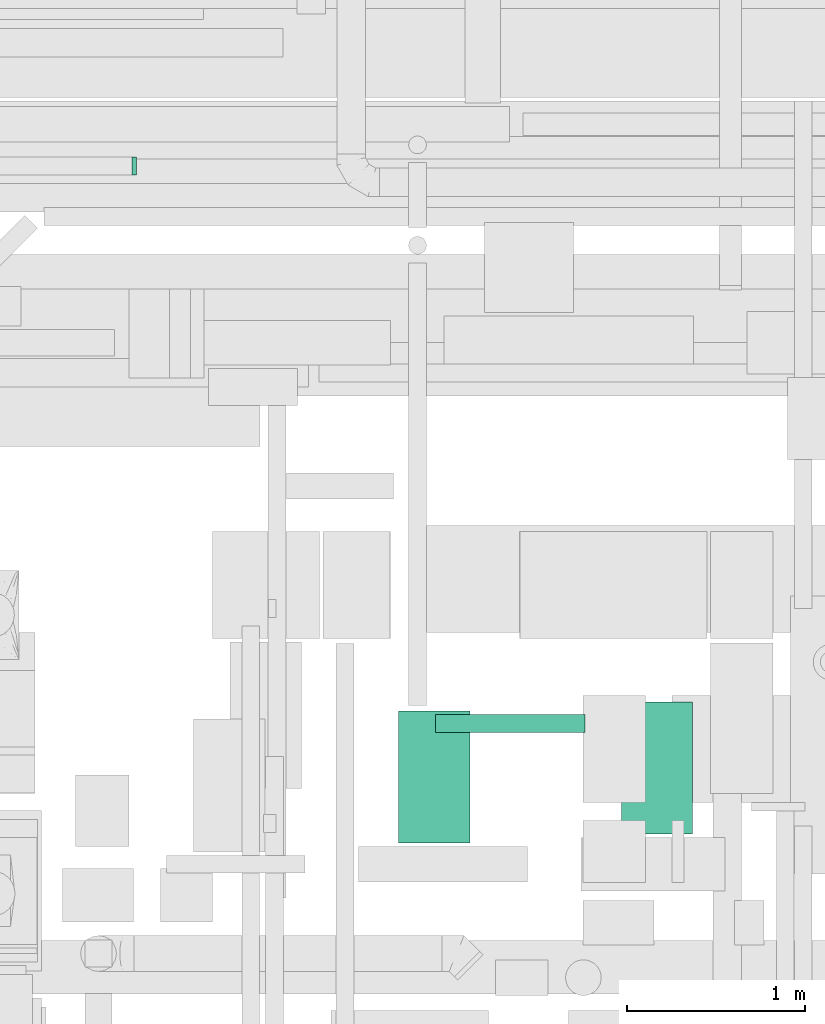
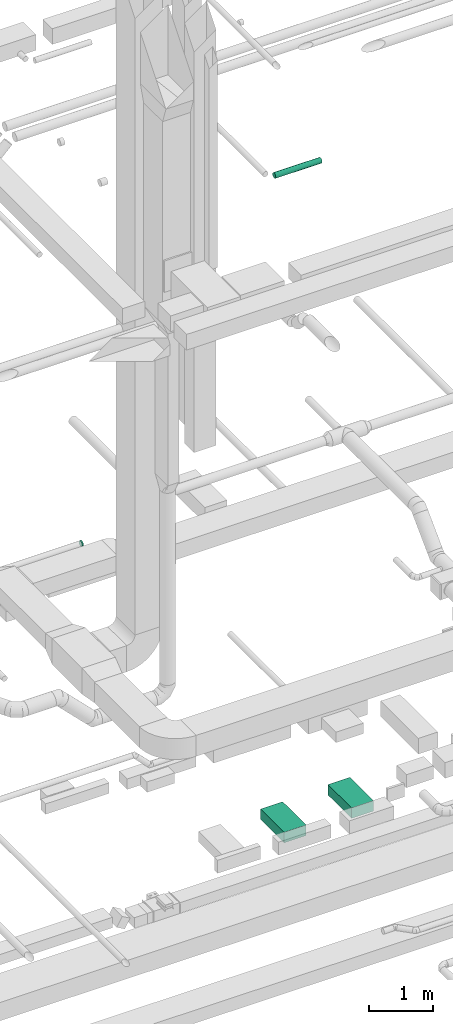
# One storey, part 136 of 337: 3 flow segments, 1 flow fitting.
"""IFC2X3 building model written with IfcOpenShell, lengths in millimetres."""

from ifc_helpers import new_model, entity, si_unit, converted_unit, derived_unit, direction, frame, origin, origin_2d_with_axis, place, context, subcontext, project, spatial, rectangle, circle, extrude, source, transform, mapped, material, type_object, type_shapes, element, save


model = new_model("IFC2X3")

# Units and contexts
model_context = context("Model", 3, precision=0.01, world=origin(), true_north=direction((6.12303176911189e-17, 1.0)))
body_context = subcontext(model_context, "Body", "Model", "MODEL_VIEW")
ifc_project = project(units=[si_unit("LENGTHUNIT", "METRE", prefix="MILLI"), si_unit("AREAUNIT", "SQUARE_METRE"), si_unit("VOLUMEUNIT", "CUBIC_METRE"), converted_unit("PLANEANGLEUNIT", "DEGREE", entity("IfcRatioMeasure", 0.0174532925199433), si_unit("PLANEANGLEUNIT", "RADIAN"), dimensions=[0, 0, 0, 0, 0, 0, 0]), si_unit("MASSUNIT", "GRAM", prefix="KILO"), derived_unit("MASSDENSITYUNIT", [(si_unit("MASSUNIT", "GRAM", prefix="KILO"), 1), (si_unit("LENGTHUNIT", "METRE"), -3)]), derived_unit("MOMENTOFINERTIAUNIT", [(si_unit("LENGTHUNIT", "METRE"), 4)]), si_unit("TIMEUNIT", "SECOND"), si_unit("FREQUENCYUNIT", "HERTZ"), si_unit("THERMODYNAMICTEMPERATUREUNIT", "DEGREE_CELSIUS"), derived_unit("THERMALTRANSMITTANCEUNIT", [(si_unit("MASSUNIT", "GRAM", prefix="KILO"), 1), (si_unit("THERMODYNAMICTEMPERATUREUNIT", "KELVIN"), -1), (si_unit("TIMEUNIT", "SECOND"), -3)]), derived_unit("VOLUMETRICFLOWRATEUNIT", [(si_unit("LENGTHUNIT", "METRE"), 3), (si_unit("TIMEUNIT", "SECOND"), -1)]), derived_unit("MASSFLOWRATEUNIT", [(si_unit("MASSUNIT", "GRAM", prefix="KILO"), 1), (si_unit("TIMEUNIT", "SECOND"), -1)]), derived_unit("ROTATIONALFREQUENCYUNIT", [(si_unit("TIMEUNIT", "SECOND"), -1)]), si_unit("ELECTRICCURRENTUNIT", "AMPERE"), si_unit("ELECTRICVOLTAGEUNIT", "VOLT"), si_unit("POWERUNIT", "WATT"), si_unit("FORCEUNIT", "NEWTON", prefix="KILO"), si_unit("ILLUMINANCEUNIT", "LUX"), si_unit("LUMINOUSFLUXUNIT", "LUMEN"), si_unit("LUMINOUSINTENSITYUNIT", "CANDELA"), derived_unit("USERDEFINED", [(si_unit("MASSUNIT", "GRAM", prefix="KILO"), -1), (si_unit("LENGTHUNIT", "METRE"), -2), (si_unit("TIMEUNIT", "SECOND"), 3), (si_unit("LUMINOUSFLUXUNIT", "LUMEN"), 1)]), derived_unit("LINEARVELOCITYUNIT", [(si_unit("LENGTHUNIT", "METRE"), 1), (si_unit("TIMEUNIT", "SECOND"), -1)]), si_unit("PRESSUREUNIT", "PASCAL"), derived_unit("USERDEFINED", [(si_unit("LENGTHUNIT", "METRE"), -2), (si_unit("MASSUNIT", "GRAM", prefix="KILO"), 1), (si_unit("TIMEUNIT", "SECOND"), -2)]), derived_unit("LINEARFORCEUNIT", [(si_unit("MASSUNIT", "GRAM", prefix="KILO"), 1), (si_unit("LENGTHUNIT", "METRE"), 1), (si_unit("TIMEUNIT", "SECOND"), -2), (si_unit("LENGTHUNIT", "METRE"), -1)]), derived_unit("PLANARFORCEUNIT", [(si_unit("MASSUNIT", "GRAM", prefix="KILO"), 1), (si_unit("LENGTHUNIT", "METRE"), 1), (si_unit("TIMEUNIT", "SECOND"), -2), (si_unit("LENGTHUNIT", "METRE"), -2)])], contexts=[model_context])

# Site, building, storey
site_placement = place(None, origin())
site = spatial("IfcSite", under=ifc_project, at=site_placement, CompositionType="ELEMENT")
building_placement = place(site_placement, origin())
building = spatial("IfcBuilding", under=site, at=building_placement, CompositionType="ELEMENT")
storey_placement = place(building_placement, origin())
storey = spatial("IfcBuildingStorey", under=building, at=storey_placement, CompositionType="ELEMENT", Elevation=0.0)

# Flow segments
duct_segment_type_1 = type_object("IfcDuctSegmentType", PredefinedType="NOTDEFINED")
for number, where in (
    (1, (27870.02, 11568.59, -850.0)),
    (2, (26620.16, 11518.59, -850.0)),
):
    element("IfcFlowSegment", number, at=place(storey_placement, frame(where)), inside=storey, type_object=duct_segment_type_1, context=body_context, shape_type="SweptSolid", body=[
        extrude(rectangle(XDim=740.000000000001, YDim=400.0, at=origin_2d_with_axis()), frame((200.0, 370.0, 0.0), z_axis=(0.0, 0.0, 1.0), x_axis=(0.0, 1.0, 0.0)), (0.0, 0.0, 1.0), 200.0),
    ])
duct_segment_type_2 = type_object("IfcDuctSegmentType", PredefinedType="NOTDEFINED")
flow_segment_placement = place(storey_placement, frame((26826.2, 12136.69, 11398.4)))
element("IfcFlowSegment", 3, at=flow_segment_placement, inside=storey, type_object=duct_segment_type_2, context=body_context, shape_type="SweptSolid", body=[
    extrude(circle(Radius=50.0, at=origin_2d_with_axis()), frame((0.0, 51.6, 51.6), z_axis=(1.0, 0.0, 0.0), x_axis=(0.0, 1.0, 0.0)), (0.0, 0.0, 1.0), 840.000000000034),
])

# Flow fitting
ifc_material = material()
duct_fitting_type = type_object("IfcDuctFittingType", PredefinedType="NOTDEFINED", material=ifc_material)
shared_shape = source(origin(), body_context, "Body", "SweptSolid", [
    extrude(circle(Radius=49.9999999999997, at=origin_2d_with_axis()), frame((0.0, 0.0, 0.0), z_axis=(1.0, 0.0, 0.0), x_axis=(0.0, 1.0, 0.0)), (0.0, 0.0, 1.0), 25.0000000000018),
])
type_shapes(duct_fitting_type, [shared_shape])
flow_fitting_placement = place(storey_placement, frame((25124.69, 15316.13, 3100.0)))
element("IfcFlowFitting", 4, at=flow_fitting_placement, inside=storey, type_object=duct_fitting_type, material=ifc_material, context=body_context, shape_type="MappedRepresentation", body=[
    mapped(shared_shape, transform((0.0, 0.0, 0.0), scale=1.0)),
])

save(model, "model.ifc")
